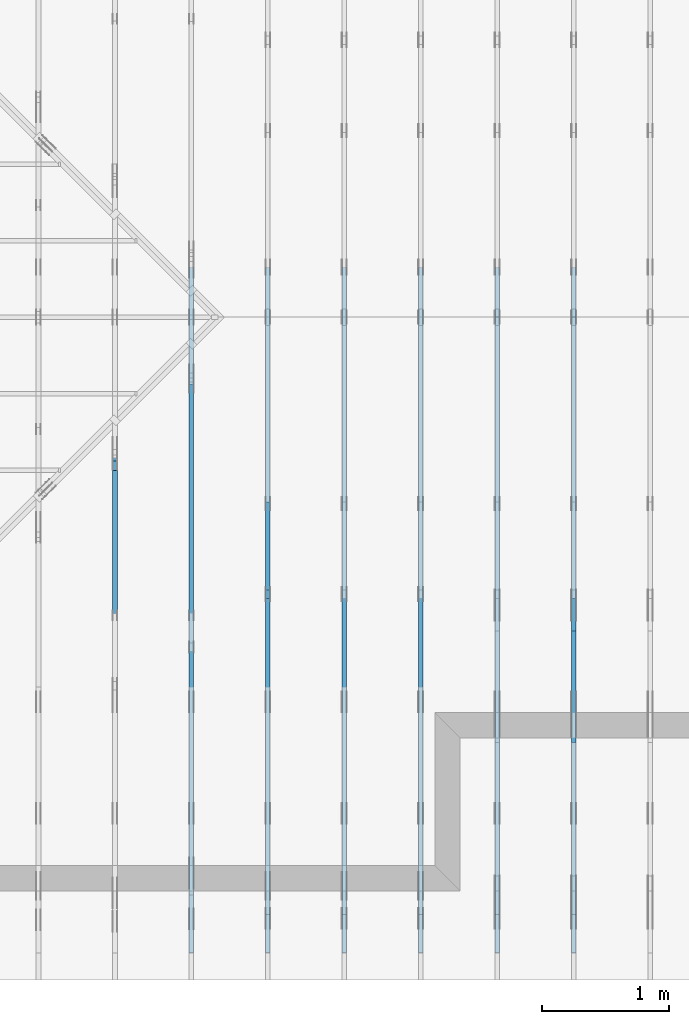
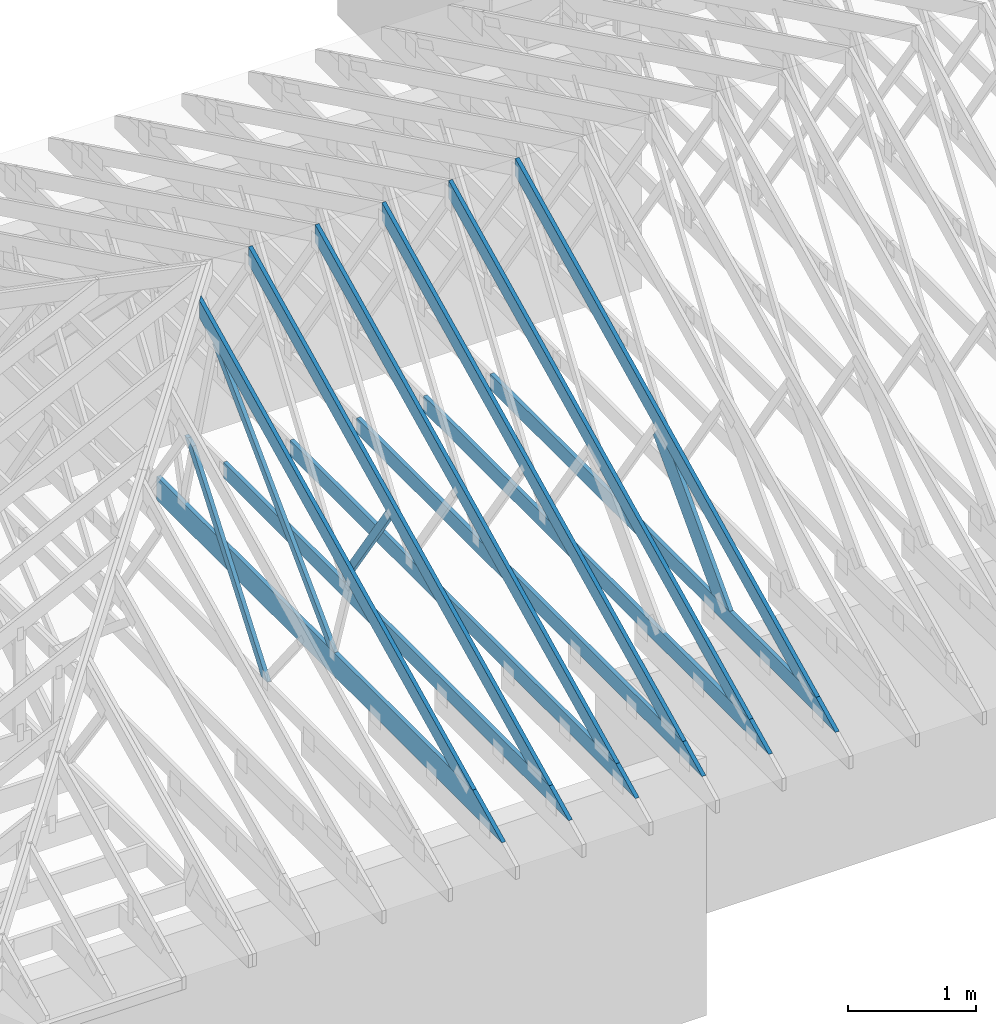
# One storey, part 5 of 159: 16 members, 7 elements without a shape of their own.
"""IFC2X3 building model written with IfcOpenShell, lengths in millimetres."""

from ifc_helpers import new_model, si_unit, frame, origin, origin_with_axes, origin_2d, place, context, project, spatial, faceted_brep, element, aggregate, save


model = new_model("IFC2X3")

# Units and contexts
model_context = context("Model", 3, precision=1e-05, world=origin())
plan_context = context("Plan", 2, precision=1e-05, world=origin_2d())
ifc_project = project(units=[si_unit("LENGTHUNIT", "METRE", prefix="MILLI"), si_unit("AREAUNIT", "SQUARE_METRE"), si_unit("VOLUMEUNIT", "CUBIC_METRE"), si_unit("SOLIDANGLEUNIT", "STERADIAN"), si_unit("PLANEANGLEUNIT", "RADIAN"), si_unit("MASSUNIT", "GRAM"), si_unit("TIMEUNIT", "SECOND"), si_unit("THERMODYNAMICTEMPERATUREUNIT", "DEGREE_CELSIUS"), si_unit("LUMINOUSINTENSITYUNIT", "LUMEN")], contexts=[model_context, plan_context])

# Site, building, storey
site_placement = place(None, origin_with_axes())
site = spatial("IfcSite", under=ifc_project, at=site_placement, CompositionType="ELEMENT")
building_placement = place(site_placement, origin_with_axes())
building = spatial("IfcBuilding", under=site, at=building_placement, Name="Plan 1", CompositionType="ELEMENT")
storey_placement = place(building_placement, origin_with_axes())
storey = spatial("IfcBuildingStorey", under=building, at=storey_placement, Name="Etasje 1", CompositionType="ELEMENT", Elevation=0.0)

# Assembly, members
assembly_1_placement = place(storey_placement, frame((7275.0222614047525, 9699.99999999999, 1.1021457184401395e-15), z_axis=(-1.0, 1.836909530733566e-16, 6.123031769111886e-17), x_axis=(-1.836909530733566e-16, -1.0, 0.0)))
assembly_1 = element("IfcElementAssembly", 1, at=assembly_1_placement, inside=storey, Name="T2 (90)", AssemblyPlace="FACTORY", PredefinedType="TRUSS")
member_1_placement = place(assembly_1_placement, frame((5135.120455399391, 2523.187516882459, -36.0), z_axis=(0.0, 0.0, 1.0), x_axis=(0.8987940462991668, -0.4383711467890778, 0.0)))
member_1 = element("IfcMember", 2, at=member_1_placement, Name="T2-O3", context=model_context, shape_type="Brep", body=[
    faceted_brep([(5212.955657516367, 148.00034936960947, 36.0), (2.9272871415741974e-05, 148.00034936960947, 36.0), (72.18443128276795, 0.00027202273031434743, 36.0), (4909.50997264878, 0.00027202273031434743, 36.0), (2.9272871415741974e-05, 148.00034936960947, 3.584774433034307e-21), (5212.955657516367, 148.00034936960947, 6.383818620388851e-13), (4909.50997264878, 0.00027202273031434743, 6.012217106660022e-13), (72.18443128276795, 0.00027202273031434743, 8.83975131959324e-15), (72.18442310739601, 0.00018235889274720307, -7.888609052210118e-31), (72.18442310739601, 0.00018235889274720307, 36.0), (2.842170943040401e-14, 148.00018235817151, 36.0), (2.842170943040401e-14, 148.00018235817151, -2.3665827156630354e-30), (4909.510346538232, 0.0001823580668906902, 2.246999438374223e-28), (4909.510346538232, 0.0001823580668928945, 36.0), (72.18442310739601, 0.00018235889269189838, 36.0), (72.18442310739601, 0.0001823588926896941, 3.303759786827862e-30), (5212.955315092269, 148.00018235821926, -2.524354896707238e-29), (5212.955315092269, 148.00018235821926, 36.0), (4909.51034653823, 0.00018235807056043996, 36.0), (4909.51034653823, 0.00018235807056043996, -2.524354896707238e-29), (0.0, 148.00018235817151, 0.0), (0.0, 148.00018235817151, 36.0), (5212.95531509227, 148.00018235821864, 36.0), (5212.95531509227, 148.00018235821867, -1.1044052673094165e-29)], [[[0, 1, 2, 3]], [[4, 5, 6, 7]], [[8, 9, 10, 11]], [[12, 13, 14, 15]], [[16, 17, 18, 19]], [[20, 21, 22, 23]]]),
])
member_2_placement = place(assembly_1_placement, frame((10188.817634446803, 370.99999999999994, -36.0), z_axis=(0.0, 0.0, 1.0), x_axis=(-1.0, 1.2246063538223773e-16, 0.0)))
member_2 = element("IfcMember", 3, at=member_2_placement, Name="T2-U32", context=model_context, shape_type="Brep", body=[
    faceted_brep([(5379.999763353053, 148.0000000000006, 36.0), (0.00025163430291286204, 148.0000000000006, 36.0), (303.4445875718029, 0.0, 36.0), (5379.999763353053, 0.0, 36.0), (0.00025163430291286204, 148.0000000000006, 3.081529661867556e-20), (5379.999763353053, 148.0000000000006, 6.588381893765035e-13), (5379.999763353053, 0.0, 6.588381893765035e-13), (303.4445875718029, 0.0, 3.716001699734406e-14), (303.4449685537348, 1.2789769243681803e-13, -3.99587178143416e-30), (303.4449685537348, 1.2789769243681803e-13, 36.0), (7.105427357601002e-15, 148.00000000000009, 36.0), (7.105427357601002e-15, 148.00000000000009, -2.9555199832572376e-30), (5380.0, -8.745704898130424e-13, 6.051131012552325e-29), (5380.0, -8.723661983761621e-13, 36.0), (303.4449685537347, 6.015103367954605e-14, 36.0), (303.4449685537347, 5.794674224266577e-14, 3.4129837543094226e-30), (5380.0, 148.00000000000006, 0.0), (5380.0, 148.00000000000006, 36.0), (5380.0, 1.1368683772161603e-13, 36.0), (5380.0, 1.1368683772161603e-13, 0.0), (0.0, 148.00000000000006, 0.0), (-1.3496946496399237e-31, 148.00000000000006, 36.0), (5380.0, 147.99999999999972, 36.0), (5380.0, 147.99999999999972, -2.0510383535746307e-29)], [[[0, 1, 2, 3]], [[4, 5, 6, 7]], [[8, 9, 10, 11]], [[12, 13, 14, 15]], [[16, 17, 18, 19]], [[20, 21, 22, 23]]]),
])
member_3_placement = place(assembly_1_placement, frame((7335.335212521153, 1346.8364569956243, -36.0), z_axis=(0.0, 0.0, 1.0), x_axis=(0.6895311389452021, -0.7242560378933215, 0.0)))
member_3 = element("IfcMember", 4, at=member_3_placement, Name="T2-D3", context=model_context, shape_type="Brep", body=[
    faceted_brep([(1535.8706779051545, 197.99998461177984, 36.0), (266.10350628432207, 197.99998461177984, 36.0), (0.0, 99.00008397742658, 36.0), (21.14596757174968, 0.0, 36.0), (1347.3640424637342, 0.0, 36.0), (266.10350628432207, 197.99998461177984, 3.258720445701937e-14), (1535.8706779051545, 197.99998461177984, 1.880836990812134e-13), (1347.3640424637342, 0.0, 1.6499905673128923e-13), (21.14596757174968, 0.0, 2.5895486246086602e-15), (0.0, 99.00008397742658, 0.0), (0.00014664980380274528, 99.00020530045005, 1.5777218104420236e-30), (0.00014664980380274528, 99.00020530045005, 36.0), (266.10369462794824, 198.00020530010084, 36.0), (266.10369462794824, 198.00020530010084, 3.1554436208840472e-30), (21.146100291866794, 0.00020530010078800842, -2.0402049895968374e-31), (21.146100291866798, 0.0002053001007888966, 36.0), (0.00014664980384182513, 99.00020530045008, 36.0), (0.00014664980383827242, 99.00020530045008, -2.2174136190568693e-30), (1347.3641191793167, 0.00020530010172270798, -1.543300326584409e-30), (1347.3641191793167, 0.00020530010172491227, 36.0), (21.146100291866787, 0.00020530010079060828, 36.0), (21.146100291866787, 0.000205300100788404, -2.4221578316207596e-32), (1535.8708880124423, 198.00020530010443, 1.262177448353619e-29), (1535.8708880124423, 198.00020530010443, 36.0), (1347.364119179317, 0.00020530010181118996, 36.0), (1347.364119179317, 0.00020530010181118996, 1.262177448353619e-29), (266.10369462794824, 198.00020530010084, 1.5777218104420236e-30), (266.10369462794824, 198.00020530010082, 36.0), (1535.8708880124425, 198.0002053001047, 36.0), (1535.8708880124425, 198.0002053001047, 1.735493991486226e-29)], [[[0, 1, 2, 3, 4]], [[5, 6, 7, 8, 9]], [[10, 11, 12, 13]], [[14, 15, 16, 17]], [[18, 19, 20, 21]], [[22, 23, 24, 25]], [[26, 27, 28, 29]]]),
])
aggregate(assembly_1, [member_1, member_2, member_3])

assembly_2_placement = place(storey_placement, frame((6675.0222614047525, 9699.99999999999, 1.1021457184401395e-15), z_axis=(-1.0, 1.836909530733566e-16, 6.123031769111886e-17), x_axis=(-1.836909530733566e-16, -1.0, 0.0)))
assembly_2 = element("IfcElementAssembly", 5, at=assembly_2_placement, inside=storey, Name="T2 (89)", AssemblyPlace="FACTORY", PredefinedType="TRUSS")
member_4_placement = place(assembly_2_placement, frame((5135.120455399391, 2523.187516882459, -36.0), z_axis=(0.0, 0.0, 1.0), x_axis=(0.8987940462991668, -0.4383711467890778, 0.0)))
member_4 = element("IfcMember", 6, at=member_4_placement, Name="T2-O3", context=model_context, shape_type="Brep", body=[
    faceted_brep([(5212.955657516367, 148.00034936960947, 36.0), (2.9272871415741974e-05, 148.00034936960947, 36.0), (72.18443128276795, 0.00027202273031434743, 36.0), (4909.50997264878, 0.00027202273031434743, 36.0), (2.9272871415741974e-05, 148.00034936960947, 3.584774433034307e-21), (5212.955657516367, 148.00034936960947, 6.383818620388851e-13), (4909.50997264878, 0.00027202273031434743, 6.012217106660022e-13), (72.18443128276795, 0.00027202273031434743, 8.83975131959324e-15), (72.18442310739601, 0.00018235889274720307, -7.888609052210118e-31), (72.18442310739601, 0.00018235889274720307, 36.0), (2.842170943040401e-14, 148.00018235817151, 36.0), (2.842170943040401e-14, 148.00018235817151, -2.3665827156630354e-30), (4909.510346538232, 0.0001823580668906902, 2.246999438374223e-28), (4909.510346538232, 0.0001823580668928945, 36.0), (72.18442310739601, 0.00018235889269189838, 36.0), (72.18442310739601, 0.0001823588926896941, 3.303759786827862e-30), (5212.955315092269, 148.00018235821926, -2.524354896707238e-29), (5212.955315092269, 148.00018235821926, 36.0), (4909.51034653823, 0.00018235807056043996, 36.0), (4909.51034653823, 0.00018235807056043996, -2.524354896707238e-29), (0.0, 148.00018235817151, 0.0), (0.0, 148.00018235817151, 36.0), (5212.95531509227, 148.00018235821864, 36.0), (5212.95531509227, 148.00018235821867, -1.1044052673094165e-29)], [[[0, 1, 2, 3]], [[4, 5, 6, 7]], [[8, 9, 10, 11]], [[12, 13, 14, 15]], [[16, 17, 18, 19]], [[20, 21, 22, 23]]]),
])
member_5_placement = place(assembly_2_placement, frame((10188.817634446803, 370.99999999999994, -36.0), z_axis=(0.0, 0.0, 1.0), x_axis=(-1.0, 1.2246063538223773e-16, 0.0)))
member_5 = element("IfcMember", 7, at=member_5_placement, Name="T2-U32", context=model_context, shape_type="Brep", body=[
    faceted_brep([(5379.999763353053, 148.0000000000006, 36.0), (0.00025163430291286204, 148.0000000000006, 36.0), (303.4445875718029, 0.0, 36.0), (5379.999763353053, 0.0, 36.0), (0.00025163430291286204, 148.0000000000006, 3.081529661867556e-20), (5379.999763353053, 148.0000000000006, 6.588381893765035e-13), (5379.999763353053, 0.0, 6.588381893765035e-13), (303.4445875718029, 0.0, 3.716001699734406e-14), (303.4449685537348, 1.2789769243681803e-13, -3.99587178143416e-30), (303.4449685537348, 1.2789769243681803e-13, 36.0), (7.105427357601002e-15, 148.00000000000009, 36.0), (7.105427357601002e-15, 148.00000000000009, -2.9555199832572376e-30), (5380.0, -8.745704898130424e-13, 6.051131012552325e-29), (5380.0, -8.723661983761621e-13, 36.0), (303.4449685537347, 6.015103367954605e-14, 36.0), (303.4449685537347, 5.794674224266577e-14, 3.4129837543094226e-30), (5380.0, 148.00000000000006, 0.0), (5380.0, 148.00000000000006, 36.0), (5380.0, 1.1368683772161603e-13, 36.0), (5380.0, 1.1368683772161603e-13, 0.0), (0.0, 148.00000000000006, 0.0), (-1.3496946496399237e-31, 148.00000000000006, 36.0), (5380.0, 147.99999999999972, 36.0), (5380.0, 147.99999999999972, -2.0510383535746307e-29)], [[[0, 1, 2, 3]], [[4, 5, 6, 7]], [[8, 9, 10, 11]], [[12, 13, 14, 15]], [[16, 17, 18, 19]], [[20, 21, 22, 23]]]),
])
aggregate(assembly_2, [member_4, member_5])

assembly_3_placement = place(storey_placement, frame((5475.0222614047525, 9699.99999999999, 1.1021457184401395e-15), z_axis=(-1.0, 1.836909530733566e-16, 6.123031769111886e-17), x_axis=(-1.836909530733566e-16, -1.0, 0.0)))
assembly_3 = element("IfcElementAssembly", 8, at=assembly_3_placement, inside=storey, Name="T1 (87)", AssemblyPlace="FACTORY", PredefinedType="TRUSS")
member_6_placement = place(assembly_3_placement, frame((5135.120455399391, 2523.187516882459, -36.0), z_axis=(0.0, 0.0, 1.0), x_axis=(0.8987940462991668, -0.4383711467890778, 0.0)))
member_6 = element("IfcMember", 9, at=member_6_placement, Name="T1-O3", context=model_context, shape_type="Brep", body=[
    faceted_brep([(5212.955657516367, 148.00034936960947, 36.0), (2.9272871415741974e-05, 148.00034936960947, 36.0), (72.18443128276795, 0.00027202273031434743, 36.0), (4909.50997264878, 0.00027202273031434743, 36.0), (2.9272871415741974e-05, 148.00034936960947, 3.584774433034307e-21), (5212.955657516367, 148.00034936960947, 6.383818620388851e-13), (4909.50997264878, 0.00027202273031434743, 6.012217106660022e-13), (72.18443128276795, 0.00027202273031434743, 8.83975131959324e-15), (72.18442310739601, 0.00018235889274720307, -7.888609052210118e-31), (72.18442310739601, 0.00018235889274720307, 36.0), (2.842170943040401e-14, 148.00018235817151, 36.0), (2.842170943040401e-14, 148.00018235817151, -2.3665827156630354e-30), (4909.510346538232, 0.0001823580668906902, 2.246999438374223e-28), (4909.510346538232, 0.0001823580668928945, 36.0), (72.18442310739601, 0.00018235889269189838, 36.0), (72.18442310739601, 0.0001823588926896941, 3.303759786827862e-30), (5212.955315092269, 148.00018235821926, -2.524354896707238e-29), (5212.955315092269, 148.00018235821926, 36.0), (4909.51034653823, 0.00018235807056043996, 36.0), (4909.51034653823, 0.00018235807056043996, -2.524354896707238e-29), (0.0, 148.00018235817151, 0.0), (0.0, 148.00018235817151, 36.0), (5212.95531509227, 148.00018235821864, 36.0), (5212.95531509227, 148.00018235821867, -1.1044052673094165e-29)], [[[0, 1, 2, 3]], [[4, 5, 6, 7]], [[8, 9, 10, 11]], [[12, 13, 14, 15]], [[16, 17, 18, 19]], [[20, 21, 22, 23]]]),
])
member_7_placement = place(assembly_3_placement, frame((10188.817634446803, 370.99999999999994, -36.0), z_axis=(0.0, 0.0, 1.0), x_axis=(-1.0, 1.2246063538223773e-16, 0.0)))
member_7 = element("IfcMember", 10, at=member_7_placement, Name="T1-U32", context=model_context, shape_type="Brep", body=[
    faceted_brep([(5379.999763353053, 148.0000000000006, 36.0), (0.00025163430291286204, 148.0000000000006, 36.0), (303.4445875718029, 0.0, 36.0), (5379.999763353053, 0.0, 36.0), (0.00025163430291286204, 148.0000000000006, 3.081529661867556e-20), (5379.999763353053, 148.0000000000006, 6.588381893765035e-13), (5379.999763353053, 0.0, 6.588381893765035e-13), (303.4445875718029, 0.0, 3.716001699734406e-14), (303.4449685537348, 1.2789769243681803e-13, -3.99587178143416e-30), (303.4449685537348, 1.2789769243681803e-13, 36.0), (7.105427357601002e-15, 148.00000000000009, 36.0), (7.105427357601002e-15, 148.00000000000009, -2.9555199832572376e-30), (5380.0, -8.745704898130424e-13, 6.051131012552325e-29), (5380.0, -8.723661983761621e-13, 36.0), (303.4449685537347, 6.015103367954605e-14, 36.0), (303.4449685537347, 5.794674224266577e-14, 3.4129837543094226e-30), (5380.0, 148.00000000000006, 0.0), (5380.0, 148.00000000000006, 36.0), (5380.0, 1.1368683772161603e-13, 36.0), (5380.0, 1.1368683772161603e-13, 0.0), (0.0, 148.00000000000006, 0.0), (-1.3496946496399237e-31, 148.00000000000006, 36.0), (5380.0, 147.99999999999972, 36.0), (5380.0, 147.99999999999972, -2.0510383535746307e-29)], [[[0, 1, 2, 3]], [[4, 5, 6, 7]], [[8, 9, 10, 11]], [[12, 13, 14, 15]], [[16, 17, 18, 19]], [[20, 21, 22, 23]]]),
])
aggregate(assembly_3, [member_6, member_7])

assembly_4_placement = place(storey_placement, frame((4875.0222614047525, 9699.99999999999, 1.1021457184401395e-15), z_axis=(-1.0, 1.836909530733566e-16, 6.123031769111886e-17), x_axis=(-1.836909530733566e-16, -1.0, 0.0)))
assembly_4 = element("IfcElementAssembly", 11, at=assembly_4_placement, inside=storey, Name="T1 (86)", AssemblyPlace="FACTORY", PredefinedType="TRUSS")
member_8_placement = place(assembly_4_placement, frame((5135.120455399391, 2523.187516882459, -36.0), z_axis=(0.0, 0.0, 1.0), x_axis=(0.8987940462991668, -0.4383711467890778, 0.0)))
member_8 = element("IfcMember", 12, at=member_8_placement, Name="T1-O3", context=model_context, shape_type="Brep", body=[
    faceted_brep([(5212.955657516367, 148.00034936960947, 36.0), (2.9272871415741974e-05, 148.00034936960947, 36.0), (72.18443128276795, 0.00027202273031434743, 36.0), (4909.50997264878, 0.00027202273031434743, 36.0), (2.9272871415741974e-05, 148.00034936960947, 3.584774433034307e-21), (5212.955657516367, 148.00034936960947, 6.383818620388851e-13), (4909.50997264878, 0.00027202273031434743, 6.012217106660022e-13), (72.18443128276795, 0.00027202273031434743, 8.83975131959324e-15), (72.18442310739601, 0.00018235889274720307, -7.888609052210118e-31), (72.18442310739601, 0.00018235889274720307, 36.0), (2.842170943040401e-14, 148.00018235817151, 36.0), (2.842170943040401e-14, 148.00018235817151, -2.3665827156630354e-30), (4909.510346538232, 0.0001823580668906902, 2.246999438374223e-28), (4909.510346538232, 0.0001823580668928945, 36.0), (72.18442310739601, 0.00018235889269189838, 36.0), (72.18442310739601, 0.0001823588926896941, 3.303759786827862e-30), (5212.955315092269, 148.00018235821926, -2.524354896707238e-29), (5212.955315092269, 148.00018235821926, 36.0), (4909.51034653823, 0.00018235807056043996, 36.0), (4909.51034653823, 0.00018235807056043996, -2.524354896707238e-29), (0.0, 148.00018235817151, 0.0), (0.0, 148.00018235817151, 36.0), (5212.95531509227, 148.00018235821864, 36.0), (5212.95531509227, 148.00018235821867, -1.1044052673094165e-29)], [[[0, 1, 2, 3]], [[4, 5, 6, 7]], [[8, 9, 10, 11]], [[12, 13, 14, 15]], [[16, 17, 18, 19]], [[20, 21, 22, 23]]]),
])
member_9_placement = place(assembly_4_placement, frame((10188.817634446803, 370.99999999999994, -36.0), z_axis=(0.0, 0.0, 1.0), x_axis=(-1.0, 1.2246063538223773e-16, 0.0)))
member_9 = element("IfcMember", 13, at=member_9_placement, Name="T1-U32", context=model_context, shape_type="Brep", body=[
    faceted_brep([(5379.999763353053, 148.0000000000006, 36.0), (0.00025163430291286204, 148.0000000000006, 36.0), (303.4445875718029, 0.0, 36.0), (5379.999763353053, 0.0, 36.0), (0.00025163430291286204, 148.0000000000006, 3.081529661867556e-20), (5379.999763353053, 148.0000000000006, 6.588381893765035e-13), (5379.999763353053, 0.0, 6.588381893765035e-13), (303.4445875718029, 0.0, 3.716001699734406e-14), (303.4449685537348, 1.2789769243681803e-13, -3.99587178143416e-30), (303.4449685537348, 1.2789769243681803e-13, 36.0), (7.105427357601002e-15, 148.00000000000009, 36.0), (7.105427357601002e-15, 148.00000000000009, -2.9555199832572376e-30), (5380.0, -8.745704898130424e-13, 6.051131012552325e-29), (5380.0, -8.723661983761621e-13, 36.0), (303.4449685537347, 6.015103367954605e-14, 36.0), (303.4449685537347, 5.794674224266577e-14, 3.4129837543094226e-30), (5380.0, 148.00000000000006, 0.0), (5380.0, 148.00000000000006, 36.0), (5380.0, 1.1368683772161603e-13, 36.0), (5380.0, 1.1368683772161603e-13, 0.0), (0.0, 148.00000000000006, 0.0), (-1.3496946496399237e-31, 148.00000000000006, 36.0), (5380.0, 147.99999999999972, 36.0), (5380.0, 147.99999999999972, -2.0510383535746307e-29)], [[[0, 1, 2, 3]], [[4, 5, 6, 7]], [[8, 9, 10, 11]], [[12, 13, 14, 15]], [[16, 17, 18, 19]], [[20, 21, 22, 23]]]),
])
member_10_placement = place(assembly_4_placement, frame((7346.76744651809, 1456.2902443153225, -36.0), z_axis=(0.0, 0.0, 1.0), x_axis=(-0.564247505007227, -0.8256056886269131, 0.0)))
member_10 = element("IfcMember", 14, at=member_10_placement, Name="T1-D42", context=model_context, shape_type="Brep", body=[
    faceted_brep([(1264.6472651905533, 73.00035481239047, 36.0), (8.801394596957834e-05, 73.00035481239047, 36.0), (10.714742691707215, 0.0, 36.0), (1236.1859046261452, 0.0, 36.0), (8.801394596957834e-05, 73.00035481239047, 1.0778243745932505e-20), (1264.6472651905533, 73.00035481239047, 1.5486950762964446e-13), (1236.1859046261452, 0.0, 1.5138411133108407e-13), (10.714742691707215, 0.0, 1.3121341979836537e-15), (10.714685884831852, 0.0001796189581002583, -9.62105002194463e-32), (10.714685884831855, 0.00017961895810048034, 36.0), (-2.6645352591003757e-14, 73.0001796189581, 36.0), (-2.842170943040401e-14, 73.0001796189581, 1.7622623733601546e-30), (1236.1860298817128, 0.00017961895895500981, 5.902699630823587e-29), (1236.1860298817128, 0.0001796189589572141, 36.0), (10.714685884831852, 0.0001796189580938849, 36.0), (10.714685884831852, 0.0001796189580916806, 5.1161877582816205e-31), (1264.6473849238073, 73.00017961895986, 0.0), (1264.6473849238073, 73.00017961895986, 36.0), (1236.1860298817128, 0.00017961895991902566, 36.0), (1236.1860298817128, 0.00017961895991902566, 0.0), (0.0, 73.0001796189581, 0.0), (0.0, 73.0001796189581, 36.0), (1264.6473849238073, 73.00017961895999, 36.0), (1264.6473849238073, 73.00017961895999, 4.733165431326071e-30)], [[[0, 1, 2, 3]], [[4, 5, 6, 7]], [[8, 9, 10, 11]], [[12, 13, 14, 15]], [[16, 17, 18, 19]], [[20, 21, 22, 23]]]),
])
aggregate(assembly_4, [member_8, member_9, member_10])

# Assembly, member
assembly_5_placement = place(storey_placement, frame((3675.02226140475, 9699.999999999993, 1.1021457184401395e-15), z_axis=(-1.0, 1.836909530733566e-16, 6.123031769111886e-17), x_axis=(-1.836909530733566e-16, -1.0, 0.0)))
assembly_5 = element("IfcElementAssembly", 15, at=assembly_5_placement, inside=storey, Name="V4 (5)", AssemblyPlace="FACTORY", PredefinedType="TRUSS")
member_11_placement = place(assembly_5_placement, frame((6282.522429040238, 1941.1758790002532, -36.0), z_axis=(0.0, 0.0, 1.0), x_axis=(0.6063173886105646, -0.7952227513523903, 0.0)))
member_11 = element("IfcMember", 16, at=member_11_placement, Name="V4-D15", context=model_context, shape_type="Brep", body=[
    faceted_brep([(2030.169689514476, 73.00012838012844, 36.0), (100.4766447071197, 73.00012838012844, 36.0), (27.829612873129918, 36.50029844734672, 36.0), (0.0, 4.011110286228359e-05, 36.0), (1974.5107598216282, 4.011110286228359e-05, 36.0), (100.4766447071197, 73.00012838012844, 1.2304433751909231e-14), (2030.169689514476, 73.00012838012844, 2.48615870111703e-13), (1974.5107598216282, 4.011110286228359e-05, 2.417998422168216e-13), (0.0, 4.011110286228359e-05, 0.0), (27.829612873129918, 36.50029844734672, 3.4080320748851922e-15), (27.829514799563192, 36.50007428625487, 1.1131996791923312e-30), (27.829514799563192, 36.50007428625487, 36.0), (100.47653204290327, 73.00007428638767, 36.0), (100.47653204290327, 73.00007428638767, 2.3498036037855827e-30), (9.889493867827631e-05, 7.428638673101777e-05, -3.4729405083728427e-31), (9.88949386800292e-05, 7.428638672968128e-05, 36.0), (27.829514799563178, 36.500074286254865, 36.0), (27.829514799563178, 36.500074286254865, 5.126304052236747e-31), (1974.5108164612702, 7.42863951403461e-05, -6.918607890566941e-29), (1974.5108164612702, 7.42863951425504e-05, 36.0), (9.889493867376586e-05, 7.42863867366611e-05, 36.0), (9.889493867376586e-05, 7.428638673445681e-05, -3.009265538105056e-36), (2030.1696482707207, 73.00007428639537, -3.7865323450608567e-29), (2030.1696482707207, 73.00007428639537, 36.0), (1974.5108164612698, 7.428639435147488e-05, 36.0), (1974.5108164612698, 7.428639435147488e-05, -3.7865323450608567e-29), (100.47653204290327, 73.00007428638763, -7.888609052210118e-31), (100.47653204290327, 73.00007428638763, 36.0), (2030.1696482707212, 73.00007428639479, 36.0), (2030.1696482707212, 73.0000742863948, -7.888609052210118e-30)], [[[0, 1, 2, 3, 4]], [[5, 6, 7, 8, 9]], [[10, 11, 12, 13]], [[14, 15, 16, 17]], [[18, 19, 20, 21]], [[22, 23, 24, 25]], [[26, 27, 28, 29]]]),
])
aggregate(assembly_5, [member_11])

# Assembly, members
assembly_6_placement = place(storey_placement, frame((6075.0222614047525, 9699.99999999999, 1.1021457184401395e-15), z_axis=(-1.0, 1.836909530733566e-16, 6.123031769111886e-17), x_axis=(-1.836909530733566e-16, -1.0, 0.0)))
assembly_6 = element("IfcElementAssembly", 17, at=assembly_6_placement, inside=storey, Name="T1 (88)", AssemblyPlace="FACTORY", PredefinedType="TRUSS")
member_12_placement = place(assembly_6_placement, frame((5135.120455399391, 2523.187516882459, -36.0), z_axis=(0.0, 0.0, 1.0), x_axis=(0.8987940462991668, -0.4383711467890778, 0.0)))
member_12 = element("IfcMember", 18, at=member_12_placement, Name="T1-O3", context=model_context, shape_type="Brep", body=[
    faceted_brep([(5212.955657516367, 148.00034936960947, 36.0), (2.9272871415741974e-05, 148.00034936960947, 36.0), (72.18443128276795, 0.00027202273031434743, 36.0), (4909.50997264878, 0.00027202273031434743, 36.0), (2.9272871415741974e-05, 148.00034936960947, 3.584774433034307e-21), (5212.955657516367, 148.00034936960947, 6.383818620388851e-13), (4909.50997264878, 0.00027202273031434743, 6.012217106660022e-13), (72.18443128276795, 0.00027202273031434743, 8.83975131959324e-15), (72.18442310739601, 0.00018235889274720307, -7.888609052210118e-31), (72.18442310739601, 0.00018235889274720307, 36.0), (2.842170943040401e-14, 148.00018235817151, 36.0), (2.842170943040401e-14, 148.00018235817151, -2.3665827156630354e-30), (4909.510346538232, 0.0001823580668906902, 2.246999438374223e-28), (4909.510346538232, 0.0001823580668928945, 36.0), (72.18442310739601, 0.00018235889269189838, 36.0), (72.18442310739601, 0.0001823588926896941, 3.303759786827862e-30), (5212.955315092269, 148.00018235821926, -2.524354896707238e-29), (5212.955315092269, 148.00018235821926, 36.0), (4909.51034653823, 0.00018235807056043996, 36.0), (4909.51034653823, 0.00018235807056043996, -2.524354896707238e-29), (0.0, 148.00018235817151, 0.0), (0.0, 148.00018235817151, 36.0), (5212.95531509227, 148.00018235821864, 36.0), (5212.95531509227, 148.00018235821867, -1.1044052673094165e-29)], [[[0, 1, 2, 3]], [[4, 5, 6, 7]], [[8, 9, 10, 11]], [[12, 13, 14, 15]], [[16, 17, 18, 19]], [[20, 21, 22, 23]]]),
])
member_13_placement = place(assembly_6_placement, frame((10188.817634446803, 370.99999999999994, -36.0), z_axis=(0.0, 0.0, 1.0), x_axis=(-1.0, 1.2246063538223773e-16, 0.0)))
member_13 = element("IfcMember", 19, at=member_13_placement, Name="T1-U32", context=model_context, shape_type="Brep", body=[
    faceted_brep([(5379.999763353053, 148.0000000000006, 36.0), (0.00025163430291286204, 148.0000000000006, 36.0), (303.4445875718029, 0.0, 36.0), (5379.999763353053, 0.0, 36.0), (0.00025163430291286204, 148.0000000000006, 3.081529661867556e-20), (5379.999763353053, 148.0000000000006, 6.588381893765035e-13), (5379.999763353053, 0.0, 6.588381893765035e-13), (303.4445875718029, 0.0, 3.716001699734406e-14), (303.4449685537348, 1.2789769243681803e-13, -3.99587178143416e-30), (303.4449685537348, 1.2789769243681803e-13, 36.0), (7.105427357601002e-15, 148.00000000000009, 36.0), (7.105427357601002e-15, 148.00000000000009, -2.9555199832572376e-30), (5380.0, -8.745704898130424e-13, 6.051131012552325e-29), (5380.0, -8.723661983761621e-13, 36.0), (303.4449685537347, 6.015103367954605e-14, 36.0), (303.4449685537347, 5.794674224266577e-14, 3.4129837543094226e-30), (5380.0, 148.00000000000006, 0.0), (5380.0, 148.00000000000006, 36.0), (5380.0, 1.1368683772161603e-13, 36.0), (5380.0, 1.1368683772161603e-13, 0.0), (0.0, 148.00000000000006, 0.0), (-1.3496946496399237e-31, 148.00000000000006, 36.0), (5380.0, 147.99999999999972, 36.0), (5380.0, 147.99999999999972, -2.0510383535746307e-29)], [[[0, 1, 2, 3]], [[4, 5, 6, 7]], [[8, 9, 10, 11]], [[12, 13, 14, 15]], [[16, 17, 18, 19]], [[20, 21, 22, 23]]]),
])
aggregate(assembly_6, [member_12, member_13])

assembly_7_placement = place(storey_placement, frame((4275.022261406632, 9700.000260373617, 1.1021457184401395e-15), z_axis=(-0.999999999895379, 1.4465201327097478e-05, 6.123031769111886e-17), x_axis=(-1.4465201327097478e-05, -0.999999999895379, 0.0)))
assembly_7 = element("IfcElementAssembly", 20, at=assembly_7_placement, inside=storey, Name="V13 (6)", AssemblyPlace="FACTORY", PredefinedType="TRUSS")
member_14_placement = place(assembly_7_placement, frame((5375.087776037149, 2406.1478341612683, -36.00000201084706), z_axis=(0.0, 0.0, 1.0), x_axis=(0.898794046317237, -0.4383711467520284, 0.0)))
member_14 = element("IfcMember", 21, at=member_14_placement, Name="V13-O10/", context=model_context, shape_type="Brep", body=[
    faceted_brep([(112.23934257507108, -3.552713678800501e-15, 36.000002033303964), (40.05491794810587, 148.0000030791116, 36.00000201084705), (8.965360119717047e-05, 148.00000281067423, 2.197947317483795e-06), (72.18451133534225, 7.048958039490572e-07, -2.984279490192421e-13), (4471.434653548583, 3.0785296047750564e-06, 2.010847062194898e-06), (4471.434653548583, 3.078529606979348e-06, 36.00000201084706), (112.23934104858472, 3.078530407724089e-06, 36.00000201084706), (72.18451240478589, 3.0785304128775075e-06, 2.010847062194898e-06), (8.931449883675668e-05, 148.00000307911614, 2.010847062194898e-06), (40.054917958298574, 148.00000307911523, 36.00000201084706), (4774.87948384575, 148.0000030791139, 36.00000201084706), (4774.87948384575, 148.00000307911478, 2.010847062194898e-06), (4774.879394531249, 148.00000307865776, 2.010847062194898e-06), (4774.879394531249, 148.00000307865776, 36.00000201084706), (4471.434422812016, 1.550224396851263e-06, 36.00000201084706), (4471.434422812016, 1.550224396851263e-06, 2.010847062194898e-06), (4774.879624979355, 148.0000030786523, 36.00000201084706), (40.05491794810587, 148.0000030786523, 36.00000201084706), (112.23934330210977, 3.0791106837568805e-06, 36.00000201084706), (4471.434312479355, 3.0791106837568805e-06, 36.00000201084706), (0.0, 148.00000307911523, 2.010847062194898e-06), (4774.879394531251, 148.00000307911523, 2.010847646929663e-06), (4471.4344177246085, 3.0786532079218887e-06, 2.010847609769598e-06), (72.18457031249955, 3.0786532079218887e-06, 2.0108470710346666e-06)], [[[0, 1, 2, 3]], [[4, 5, 6, 7]], [[8, 9, 10, 11]], [[12, 13, 14, 15]], [[16, 17, 18, 19]], [[20, 21, 22, 23]]]),
])
member_15_placement = place(assembly_7_placement, frame((10188.81763551198, 445.99999999999994, -36.0), z_axis=(0.0, 0.0, 1.0), x_axis=(-1.0, 1.2246063538223773e-16, 0.0)))
member_15 = element("IfcMember", 22, at=member_15_placement, Name="V13-U3", context=model_context, shape_type="Brep", body=[
    faceted_brep([(5379.9997644182295, 223.0000000000006, 36.0), (0.00025269947946071625, 223.0000000000006, 36.0), (457.21802613697946, 0.0, 36.0), (5379.9997644182295, 0.0, 36.0), (0.00025269947946071625, 223.0000000000006, 3.0945738815520044e-20), (5379.9997644182295, 223.0000000000006, 6.588381895069457e-13), (5379.9997644182295, 0.0, 6.588381895069457e-13), (457.21802613697946, 0.0, 5.599120998894708e-14), (457.2177567202597, -1.7053025658242404e-13, 1.4199496293978212e-29), (457.2177567202597, -1.7053025658242404e-13, 36.0), (1.4210854715202004e-14, 222.99999999999994, 36.0), (1.4210854715202004e-14, 222.99999999999994, 0.0), (5380.000000000001, -1.0093753207112436e-12, 7.572653393871088e-29), (5380.000000000001, -1.0071710292743633e-12, 36.0), (457.2177567202598, -1.0290046723371126e-13, 36.0), (457.2177567202598, -1.0510475867059154e-13, 6.435597764248699e-30), (5380.000000000001, 223.00000000000017, 0.0), (5380.000000000001, 223.00000000000017, 36.0), (5380.000000000001, 2.2737367544323206e-13, 36.0), (5380.000000000001, 2.2737367544323206e-13, 0.0), (0.0, 222.99999999999994, 0.0), (0.0, 222.99999999999994, 36.0), (5380.000000000001, 222.9999999999996, 36.0), (5380.000000000001, 222.9999999999996, -3.470987982972452e-29)], [[[0, 1, 2, 3]], [[4, 5, 6, 7]], [[8, 9, 10, 11]], [[12, 13, 14, 15]], [[16, 17, 18, 19]], [[20, 21, 22, 23]]]),
])
member_16_placement = place(assembly_7_placement, frame((5676.7434760055985, 2233.7785506450673, -36.0), z_axis=(0.0, 0.0, 1.0), x_axis=(0.7089439291785015, -0.705264847614673, 0.0)))
member_16 = element("IfcMember", 23, at=member_16_placement, Name="V13-D9", context=model_context, shape_type="Brep", body=[
    faceted_brep([(2608.2847010694713, 73.00007724213992, 36.0), (143.59663414018087, 73.00007724213992, 36.0), (36.690386758707064, 36.50000059150716, 36.0), (0.00011527552396728424, 0.00013415423836704576, 36.0), (2534.903811939078, 0.00013415423836704576, 36.0), (143.59663414018087, 73.00007724213992, 1.7584935055557278e-14), (2608.2847010694713, 73.00007724213992, 3.1941220175073747e-13), (2534.903811939078, 0.00013415423836704576, 3.1042593144291594e-13), (0.00011527552396728424, 0.00013415423836704576, 1.4116713909054002e-20), (36.690386758707064, 36.50000059150716, 4.4931280748913084e-15), (36.69040574298651, 36.500048131299984, -3.405532548634736e-31), (36.69040574298651, 36.500048131299984, 36.0), (143.59677194985943, 73.00004813097256, 36.0), (143.59677194985943, 73.00004813097256, -6.886553085935342e-31), (3.9706024655260935e-15, 4.813097256884384e-05, -3.447234044520866e-31), (5.525212855598746e-15, 4.813097256728112e-05, 36.0), (36.69040574298651, 36.500048131299984, 36.0), (36.69040574298651, 36.500048131299984, 2.0549672506611807e-31), (2534.9038603211366, 4.813097661009007e-05, 1.426181464738536e-28), (2534.9038603211366, 4.813097661229436e-05, 36.0), (-3.510705473250578e-30, 4.8130972575039454e-05, 36.0), (0.0, 4.813097257283516e-05, 0.0), (2608.284671806451, 73.00004813097803, 6.401722139724437e-29), (2608.284671806451, 73.00004813097803, 36.0), (2534.9038603211375, 4.813097802980337e-05, 36.0), (2534.9038603211375, 4.813097802980337e-05, 6.465513385882598e-29), (143.59677194985943, 73.00004813097257, 0.0), (143.59677194985943, 73.00004813097257, 36.0), (2608.28467180645, 73.000048130979, 36.0), (2608.28467180645, 73.000048130979, 3.1554436208840472e-30)], [[[0, 1, 2, 3, 4]], [[5, 6, 7, 8, 9]], [[10, 11, 12, 13]], [[14, 15, 16, 17]], [[18, 19, 20, 21]], [[22, 23, 24, 25]], [[26, 27, 28, 29]]]),
])
aggregate(assembly_7, [member_14, member_15, member_16])

save(model, "model.ifc")
